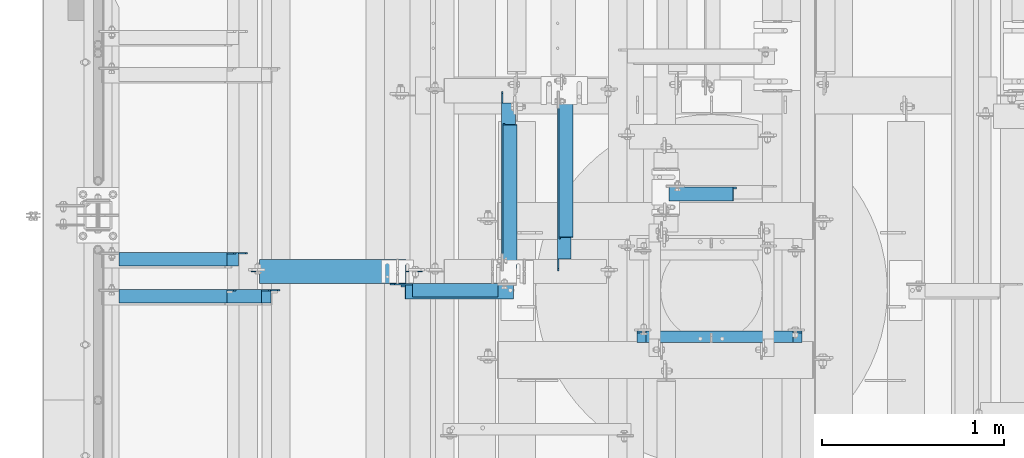
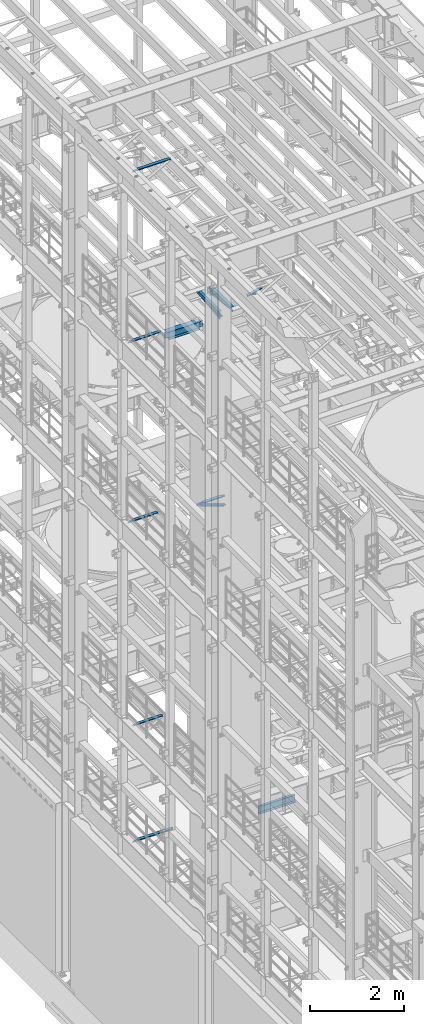
# One storey, part 1257 of 1876: 14 beams, 14 elements without a shape of their own.
"""IFC2X3 building model written with IfcOpenShell, lengths in millimetres."""

from ifc_helpers import new_model, si_unit, frame, origin_with_axes, place, context, subcontext, project, spatial, faceted_brep, material, type_object, element, aggregate, save


model = new_model("IFC2X3")

# Units and contexts
model_context = context("Model", 3, precision=1e-05, world=origin_with_axes())
body_context = subcontext(model_context, "Body", "Model", "MODEL_VIEW")
ifc_project = project(units=[si_unit("LENGTHUNIT", "METRE", prefix="MILLI"), si_unit("AREAUNIT", "SQUARE_METRE"), si_unit("VOLUMEUNIT", "CUBIC_METRE"), si_unit("MASSUNIT", "GRAM", prefix="KILO"), si_unit("TIMEUNIT", "SECOND"), si_unit("PLANEANGLEUNIT", "RADIAN"), si_unit("SOLIDANGLEUNIT", "STERADIAN"), si_unit("THERMODYNAMICTEMPERATUREUNIT", "DEGREE_CELSIUS"), si_unit("LUMINOUSINTENSITYUNIT", "LUMEN")], contexts=[model_context])

# Site, building, storey
site_placement = place(None, origin_with_axes())
site = spatial("IfcSite", under=ifc_project, at=site_placement, CompositionType="ELEMENT")
building_placement = place(site_placement, origin_with_axes())
building = spatial("IfcBuilding", under=site, at=building_placement, Name="Undefined", CompositionType="ELEMENT")
storey_placement = place(building_placement, origin_with_axes())
storey = spatial("IfcBuildingStorey", under=building, at=storey_placement, Name="Undefined", CompositionType="ELEMENT", Elevation=0.0)

# Assembly, beam
assembly_1_placement = place(storey_placement, origin_with_axes())
assembly_1 = element("IfcElementAssembly", 1, at=assembly_1_placement, inside=storey, AssemblyPlace="NOTDEFINED", PredefinedType="RIGID_FRAME")
ifc_material_1 = material(Name="STEEL/A36")
beam_type_1 = type_object("IfcBeamType", Name="L3X3X3/8", PredefinedType="NOTDEFINED")
beam_1_placement = place(assembly_1_placement, frame((2264.97513385575, 5284.27309255047, 17827.8886516946), z_axis=(1.0, 0.0, 0.0), x_axis=(1.46999992831515e-07, 0.993080008006003, 0.117439762000677)))
beam_1 = element("IfcBeam", 2, at=beam_1_placement, type_object=beam_type_1, material=ifc_material_1, ObjectType="L3X3X3/8", context=body_context, shape_type="Brep", body=[
    faceted_brep([(15.9824212601507, 38.1000000000931, -38.0999999999963), (15.9824212619769, 38.1000000000313, 38.1000000000045), (811.054095961969, 38.1000000007734, 38.0999999998535), (811.054095960143, 38.1000000008353, -38.1000000001468), (15.9824212619669, 28.5750000000226, 38.1000000000026), (811.054095961959, 28.5750000007647, 38.0999999998517), (15.9824212603689, 28.5750000000771, -28.574999999998), (811.05409596036, 28.5750000008193, -28.575000000149), (15.9824212602953, -38.1000000000167, -28.5750000000098), (811.054095960287, -38.0999999992782, -28.5750000001613), (15.9824212600679, -38.1000000000095, -38.1000000000104), (811.05409596006, -38.0999999992709, -38.1000000001613)], [[[0, 1, 2, 3]], [[1, 4, 5, 2]], [[4, 6, 7, 5]], [[6, 8, 9, 7]], [[8, 10, 11, 9]], [[10, 0, 3, 11]], [[5, 7, 9, 11, 3, 2]], [[10, 8, 6, 4, 1, 0]]]),
])
aggregate(assembly_1, [beam_1])

assembly_2_placement = place(storey_placement, origin_with_axes())
assembly_2 = element("IfcElementAssembly", 3, at=assembly_2_placement, inside=storey, Name="ANGLE", AssemblyPlace="NOTDEFINED", PredefinedType="RIGID_FRAME")
beam_2_placement = place(assembly_2_placement, frame((2255.45013319264, 5279.79849679511, 17945.1), z_axis=(1.0, 0.0, 0.0), x_axis=(0.0, 1.0, 0.0)))
beam_2 = element("IfcBeam", 4, at=beam_2_placement, type_object=beam_type_1, material=ifc_material_1, Name="ANGLE", ObjectType="L3X3X3/8", context=body_context, shape_type="Brep", body=[
    faceted_brep([(925.116190134668, 28.5750000000007, -28.5750000001863), (925.116201402728, 28.5750000000007, 38.0999999998148), (68.262074232538, 28.5750001907327, 38.0999999999872), (68.2620629644771, 28.5750000000007, -28.5750000000139), (925.116201402728, 38.0999999999985, 38.0999999998148), (68.262074232538, 38.0999999999985, 38.0999999999872), (15.8750625152097, 28.5750000000007, -28.5749999999953), (15.8750613722059, 28.5750001907327, -38.0999999999958), (3.17506156294075, 15.8750003814675, -38.0999999999995), (3.17506270594458, 15.8750003814675, -28.5749999999989), (68.2620613547542, 28.5750001907327, -38.100000000014), (68.2620613547542, 38.0999999999985, -38.100000000014), (925.116188524945, 38.0999999999985, -38.1000000001864), (925.116188524945, 28.5750001907327, -38.1000000001864), (977.503188311244, 28.5750000000007, -28.5750000001963), (977.50318670152, 28.5750001907327, -38.1000000001968), (990.203188120509, 15.8750003814675, -28.575000000199), (990.203186510787, 15.8750003814675, -38.1000000001991), (990.203188120509, 3.17500152587672, -28.575000000199), (990.203186510787, 3.17500152587672, -38.1000000001991), (990.203189649672, -38.0999999999985, -28.575000000199), (990.203188239976, -38.0999999999985, -38.1000000001995), (3.17506206535836, -38.0999999999985, -28.5749999999989), (3.17506108428279, -38.0999999999985, -38.0999999999995), (3.17506156294075, 3.17500152587672, -38.0999999999995), (3.17506270594458, 3.17500152587672, -28.5749999999989)], [[[0, 1, 2, 3]], [[1, 4, 5, 2]], [[6, 7, 8, 9]], [[3, 10, 7, 6]], [[2, 5, 11, 10, 3]], [[4, 12, 11, 5]], [[1, 0, 13, 12, 4]], [[14, 15, 13, 0]], [[16, 17, 15, 14]], [[18, 19, 17, 16]], [[19, 18, 20, 21]], [[21, 20, 22, 23]], [[8, 7, 10, 11, 12, 13, 15, 17, 19, 21, 23, 24]], [[9, 8, 24, 25]], [[20, 18, 16, 14, 0, 3, 6, 9, 25, 22]], [[24, 23, 22, 25]]]),
])
aggregate(assembly_2, [beam_2])

assembly_3_placement = place(storey_placement, origin_with_axes())
assembly_3 = element("IfcElementAssembly", 5, at=assembly_3_placement, inside=storey, AssemblyPlace="NOTDEFINED", PredefinedType="RIGID_FRAME")
beam_3_placement = place(assembly_3_placement, frame((2572.13074474911, 5275.32411137105, 17945.3636516205), z_axis=(1.0, 0.0, 0.0), x_axis=(0.0, 0.993080010016254, -0.117439745001923)))
beam_3 = element("IfcBeam", 6, at=beam_3_placement, type_object=beam_type_1, material=ifc_material_1, ObjectType="L3X3X3/8", context=body_context, shape_type="Brep", body=[
    faceted_brep([(189.245983137666, 38.1000000000895, -38.0999999999999), (189.245983137666, 38.1000000000895, 38.0999999999999), (984.31457199746, 38.1000000005843, 38.0999999999999), (984.31457199746, 38.1000000005843, -38.0999999999999), (189.245983137656, 28.5750000000953, 38.0999999999999), (984.31457199745, 28.5750000005937, 38.0999999999999), (189.245983137656, 28.5750000000953, -28.5749999999998), (984.31457199745, 28.5750000005937, -28.5749999999998), (189.245983137589, -38.0999999998603, -28.5749999999998), (984.314571997383, -38.0999999993655, -28.5749999999998), (189.245983137589, -38.0999999998603, -38.0999999999999), (984.314571997383, -38.0999999993655, -38.0999999999999)], [[[0, 1, 2, 3]], [[1, 4, 5, 2]], [[4, 6, 7, 5]], [[6, 8, 9, 7]], [[8, 10, 11, 9]], [[10, 0, 3, 11]], [[5, 7, 9, 11, 3, 2]], [[10, 8, 6, 4, 1, 0]]]),
])
aggregate(assembly_3, [beam_3])

assembly_4_placement = place(storey_placement, origin_with_axes())
assembly_4 = element("IfcElementAssembly", 7, at=assembly_4_placement, inside=storey, Name="ANGLE", AssemblyPlace="NOTDEFINED", PredefinedType="RIGID_FRAME")
beam_4_placement = place(assembly_4_placement, frame((2562.60574474912, 5279.79856567383, 17945.1), z_axis=(1.0, 0.0, 0.0), x_axis=(0.0, 1.0, 0.0)))
beam_4 = element("IfcBeam", 8, at=beam_4_placement, type_object=beam_type_1, material=ifc_material_1, Name="ANGLE", ObjectType="L3X3X3/8", context=body_context, shape_type="Brep", body=[
    faceted_brep([(925.116125485024, 28.5750000000007, -28.5749999999998), (925.116126885215, 28.5750000000007, 38.0999999999999), (68.2619997150068, 28.5750001907327, 38.0999999999999), (68.2619983148161, 28.5750000000007, -28.5749999999998), (925.116126885217, 38.0999999999985, 38.0999999999999), (68.2619997149695, 38.0999999999985, 38.0999999999999), (15.8749936676099, 28.5749999999989, -28.5750000000007), (15.8749999382144, 28.5750001907327, -38.0999999999999), (3.17500012894925, 15.8750003814675, -38.0999999999999), (3.17500032897624, 15.8750003814675, -28.5749999999998), (68.2619981147891, 28.5750001907327, -38.0999999999999), (68.2619981147864, 38.0999999999985, -38.0999999999999), (925.116125285034, 38.0999999999985, -38.0999999999999), (925.116125284997, 28.5750001907327, -38.0999999999999), (977.503123661599, 28.5750000000007, -28.5749999999998), (977.503123461572, 28.5750001907327, -38.0999999999999), (990.203123470864, 15.8750003814675, -28.5749999999998), (990.203123270837, 15.8750003814675, -38.0999999999999), (990.203123470864, 3.17500152587672, -28.5749999999998), (990.203123270837, 3.17500152587672, -38.0999999999999), (990.203125000004, -38.0999999999985, -28.5749999999998), (990.203125000004, -38.0999999999985, -38.0999999999999), (3.17499999075153, -38.0999999999985, -28.5749999999998), (3.17499999075153, -38.0999999999985, -38.0999999999999), (3.17500012894925, 3.17500152587672, -38.0999999999999), (3.17500032897624, 3.17500152587672, -28.5749999999998)], [[[0, 1, 2, 3]], [[1, 4, 5, 2]], [[6, 7, 8, 9]], [[3, 10, 7, 6]], [[2, 5, 11, 10, 3]], [[4, 12, 11, 5]], [[1, 0, 13, 12, 4]], [[14, 15, 13, 0]], [[16, 17, 15, 14]], [[18, 19, 17, 16]], [[19, 18, 20, 21]], [[21, 20, 22, 23]], [[8, 7, 10, 11, 12, 13, 15, 17, 19, 21, 23, 24]], [[9, 8, 24, 25]], [[20, 18, 16, 14, 0, 3, 6, 9, 25, 22]], [[24, 23, 22, 25]]]),
])
aggregate(assembly_4, [beam_4])

assembly_5_placement = place(storey_placement, origin_with_axes())
assembly_5 = element("IfcElementAssembly", 9, at=assembly_5_placement, inside=storey, AssemblyPlace="NOTDEFINED", PredefinedType="RIGID_FRAME")
beam_5_placement = place(assembly_5_placement, frame((3121.40550695098, 5705.49027389162, 17827.625), z_axis=(0.0, -1.0, 0.0), x_axis=(0.96921335566298, -1.16999989788286e-07, 0.246222401914391)))
beam_5 = element("IfcBeam", 10, at=beam_5_placement, type_object=beam_type_1, material=ifc_material_1, ObjectType="L3X3X3/8", context=body_context, shape_type="Brep", body=[
    faceted_brep([(26.0583260141784, 38.0999999999804, -38.1000000000095), (26.0583259932782, 38.1000000000859, 38.0999999999913), (391.609254057234, 38.1000000001732, 38.1000000000377), (391.609254078135, 38.1000000000677, -38.0999999999631), (26.0583259932764, 28.5750000000808, 38.0999999999949), (391.609254057231, 28.5750000001644, 38.1000000000413), (26.0583260115645, 28.5749999999862, -28.5750000000062), (391.609254075521, 28.5750000000698, -28.5749999999598), (26.0583260115518, -38.1000000000604, -28.5749999999844), (391.609254075506, -38.0999999999767, -28.5749999999389), (26.0583260141639, -38.1000000000713, -38.0999999999858), (391.609254078118, -38.0999999999876, -38.0999999999394)], [[[0, 1, 2, 3]], [[1, 4, 5, 2]], [[4, 6, 7, 5]], [[6, 8, 9, 7]], [[8, 10, 11, 9]], [[10, 0, 3, 11]], [[5, 7, 9, 11, 3, 2]], [[10, 8, 6, 4, 1, 0]]]),
])
aggregate(assembly_5, [beam_5])

assembly_6_placement = place(storey_placement, origin_with_axes())
assembly_6 = element("IfcElementAssembly", 11, at=assembly_6_placement, inside=storey, AssemblyPlace="NOTDEFINED", PredefinedType="RIGID_FRAME")
beam_6_placement = place(assembly_6_placement, frame((1587.51955351427, 5166.5618484497, 13273.6720682906), z_axis=(0.0, -1.0, 0.0), x_axis=(0.942990333545967, 0.0, -0.332820117839752)))
beam_6 = element("IfcBeam", 12, at=beam_6_placement, type_object=beam_type_1, material=ifc_material_1, ObjectType="L3X3X3/8", context=body_context, shape_type="Brep", body=[
    faceted_brep([(95.3968786089349, 38.100000000044, -38.1000000000004), (95.3968786089349, 38.100000000044, 38.1000000000004), (726.419164255835, 38.1000000003787, 38.1000000000004), (726.419164255835, 38.1000000003787, -38.1000000000004), (95.3968786089299, 28.5750000000462, 38.1000000000004), (726.41916425583, 28.5750000003809, 38.1000000000004), (95.3968786089299, 28.5750000000462, -28.5749999999998), (726.41916425583, 28.5750000003809, -28.5749999999998), (95.3968786088958, -38.0999999999422, -28.5749999999998), (726.419164255796, -38.0999999996093, -28.5749999999998), (95.3968786088958, -38.0999999999422, -38.1000000000004), (726.419164255796, -38.0999999996093, -38.1000000000004)], [[[0, 1, 2, 3]], [[1, 4, 5, 2]], [[4, 6, 7, 5]], [[6, 8, 9, 7]], [[8, 10, 11, 9]], [[10, 0, 3, 11]], [[5, 7, 9, 11, 3, 2]], [[10, 8, 6, 4, 1, 0]]]),
])
aggregate(assembly_6, [beam_6])

assembly_7_placement = place(storey_placement, origin_with_axes())
assembly_7 = element("IfcElementAssembly", 13, at=assembly_7_placement, inside=storey, Name="ANGLE", AssemblyPlace="NOTDEFINED", PredefinedType="RIGID_FRAME")
beam_7_placement = place(assembly_7_placement, frame((1600.2, 5176.08684844971, 13271.5), z_axis=(0.0, -1.0, 0.0), x_axis=(1.0, 0.0, 0.0)))
beam_7 = element("IfcBeam", 14, at=beam_7_placement, type_object=beam_type_1, material=ifc_material_1, Name="ANGLE", ObjectType="L3X3X3/8", context=body_context, shape_type="Brep", body=[
    faceted_brep([(128.586999858062, 38.1000000000004, 38.1000000000004), (128.586999858057, 28.5750000000007, 38.1000000000004), (598.488001267657, 28.5750000000007, 38.1000000000004), (598.488001267657, 38.1000000000004, 38.1000000000004), (128.586999057965, 28.5750000000007, -28.5749999999998), (598.488000334217, 28.5750000000007, -28.5749999999998), (672.306247175647, 22.2250007629409, -28.5749999999998), (672.306247042299, 22.2250007629409, -38.1000000000004), (598.488000200868, 22.2250007629409, -38.1000000000004), (598.488000334217, 22.2250007629409, -28.5749999999998), (598.488000200868, 38.1000000000004, -38.1000000000004), (128.586998943671, 38.1000000000004, -38.1000000000004), (128.586998943663, 19.0499996185299, -38.1000000000004), (128.586999057964, 19.0499996185299, -28.5749999999998), (30.9562521022438, 19.0499996185299, -38.1000000000004), (30.9562522165447, 19.0499996185299, -28.5749999999998), (5.55625248371348, -6.35000000000036, -38.1000000000004), (5.55625259801445, -6.35000000000036, -28.5749999999998), (5.55625000000055, -38.1000000000004, -38.1000000000004), (5.55625000000055, -38.1000000000004, -28.5749999999998), (697.70625, -38.1000000000004, -28.5749999999998), (697.706246794178, -3.175000762938, -28.5749999999998), (697.706246660829, -3.175000762938, -38.1000000000004), (697.70625, -38.1000000000004, -38.1000000000004)], [[[0, 1, 2, 3]], [[1, 4, 5, 2]], [[6, 7, 8, 9]], [[2, 5, 9, 8, 10, 3]], [[11, 0, 3, 10]], [[1, 0, 11, 12, 13, 4]], [[13, 12, 14, 15]], [[15, 14, 16, 17]], [[16, 18, 19, 17]], [[6, 9, 5, 4, 13, 15, 17, 19, 20, 21]], [[7, 6, 21, 22]], [[18, 16, 14, 12, 11, 10, 8, 7, 22, 23]], [[19, 18, 23, 20]], [[22, 21, 20, 23]]]),
])
aggregate(assembly_7, [beam_7])

assembly_8_placement = place(storey_placement, origin_with_axes())
assembly_8 = element("IfcElementAssembly", 15, at=assembly_8_placement, inside=storey, Name="ANGLE", AssemblyPlace="NOTDEFINED", PredefinedType="RIGID_FRAME")
beam_8_placement = place(assembly_8_placement, frame((4.51516825708356e-09, 5143.5, 22517.1), z_axis=(0.0, -1.0, 0.0), x_axis=(1.0, 0.0, 0.0)))
beam_8 = element("IfcBeam", 16, at=beam_8_placement, type_object=beam_type_1, material=ifc_material_1, Name="ANGLE", ObjectType="L3X3X3/8", context=body_context, shape_type="Brep", body=[
    faceted_brep([(115.886999817316, 28.5750000000007, 38.0999999999999), (115.886999817316, 38.0999999999985, 38.0999999999999), (115.886998826692, 38.0999999999985, -38.0999999999999), (115.88699882669, 12.699999237062, -38.0999999999999), (115.886998950515, 12.699999237062, -28.5749999999998), (115.88699895052, 28.5750000000007, -28.5749999999998), (38.8937432114558, 12.699999237062, -38.0999999999999), (38.8937433352807, 12.699999237062, -28.5749999999998), (7.14374321145577, -19.050000762938, -38.0999999999999), (7.14374333528067, -19.050000762938, -28.5749999999998), (7.1437499954859, -38.0999999999985, -38.0999999999999), (7.1437499954859, -38.0999999999985, -28.5749999999998), (949.325002419604, 15.8750003814712, -28.5749999999998), (936.625002610339, 28.5750000000007, -28.5749999999998), (900.113000619098, 28.5750000000007, -28.5749999999998), (949.324999995485, -38.0999999999985, -28.5749999999998), (949.325002419604, 3.17500152588036, -28.5749999999998), (900.11300241932, 28.5750000000007, 38.0999999999999), (900.1130024193, 38.0999999999985, 38.0999999999999), (900.113000361957, 38.0999999999985, -38.0999999999999), (900.113000361924, 28.5750001907363, -38.0999999999999), (936.625002353164, 28.5750001907363, -38.0999999999999), (949.325002162429, 15.8750003814712, -38.0999999999999), (949.325002162429, 3.17500152588036, -38.0999999999999), (949.324999995485, -38.0999999999985, -38.0999999999999)], [[[0, 1, 2, 3, 4, 5]], [[4, 3, 6, 7]], [[7, 6, 8, 9]], [[8, 10, 11, 9]], [[12, 13, 14, 5, 4, 7, 9, 11, 15, 16]], [[0, 5, 14, 17]], [[1, 0, 17, 18]], [[2, 1, 18, 19]], [[17, 14, 20, 19, 18]], [[13, 21, 20, 14]], [[12, 22, 21, 13]], [[16, 23, 22, 12]], [[10, 8, 6, 3, 2, 19, 20, 21, 22, 23, 24]], [[11, 10, 24, 15]], [[23, 16, 15, 24]]]),
])
aggregate(assembly_8, [beam_8])

assembly_9_placement = place(storey_placement, origin_with_axes())
assembly_9 = element("IfcElementAssembly", 17, at=assembly_9_placement, inside=storey, Name="ANGLE", AssemblyPlace="NOTDEFINED", PredefinedType="RIGID_FRAME")
beam_9_placement = place(assembly_9_placement, frame((-1.44313229599957e-09, 5346.7, 17945.1), z_axis=(0.0, -1.0, 0.0), x_axis=(1.0, 0.0, 0.0)))
beam_9 = element("IfcBeam", 18, at=beam_9_placement, type_object=beam_type_1, material=ifc_material_1, Name="ANGLE", ObjectType="L3X3X3/8", context=body_context, shape_type="Brep", body=[
    faceted_brep([(773.112500001443, 28.5750000000007, -28.5749999999998), (773.112500001443, 28.5750000000007, 38.0999999999999), (115.886999817316, 28.5750000000007, 38.0999999999999), (115.88699895052, 28.5750000000007, -28.5749999999998), (773.112500001443, 38.0999999999985, 38.0999999999999), (115.886999817316, 38.0999999999985, 38.0999999999999), (115.886998950515, 12.699999237062, -28.5749999999998), (115.88699882669, 12.699999237062, -38.0999999999999), (38.8937432114558, 12.699999237062, -38.0999999999999), (38.8937433352807, 12.699999237062, -28.5749999999998), (115.886998826692, 38.0999999999985, -38.0999999999999), (773.112500001443, 38.0999999999985, -38.1000000000004), (773.112500001443, 28.5750000000007, -38.1000000000004), (809.625001718057, 28.5750000000007, -28.5749999999998), (809.625001718057, 28.5750000000007, -38.1000000000004), (822.325001527322, 15.8750001907356, -28.5749999999998), (822.325001527322, 15.8750001907356, -38.1000000000004), (822.325001527322, -38.1000030517571, -28.5749999999998), (822.325001527322, -38.0999999999985, -38.1000000000004), (7.1437499954859, -38.0999999999985, -28.5749999999998), (7.1437499954859, -38.0999999999985, -38.0999999999999), (7.14374321145577, -19.050000762938, -38.0999999999999), (7.14374333528067, -19.050000762938, -28.5749999999998)], [[[0, 1, 2, 3]], [[1, 4, 5, 2]], [[6, 7, 8, 9]], [[2, 5, 10, 7, 6, 3]], [[4, 11, 10, 5]], [[1, 0, 12, 11, 4]], [[13, 14, 12, 0]], [[15, 16, 14, 13]], [[17, 18, 16, 15]], [[18, 17, 19, 20]], [[8, 7, 10, 11, 12, 14, 16, 18, 20, 21]], [[9, 8, 21, 22]], [[17, 15, 13, 0, 3, 6, 9, 22, 19]], [[21, 20, 19, 22]]]),
])
aggregate(assembly_9, [beam_9])

assembly_10_placement = place(storey_placement, origin_with_axes())
assembly_10 = element("IfcElementAssembly", 19, at=assembly_10_placement, inside=storey, Name="ANGLE", AssemblyPlace="NOTDEFINED", PredefinedType="RIGID_FRAME")
beam_10_placement = place(assembly_10_placement, frame((0.0, 5143.5, 8115.3), z_axis=(0.0, -1.0, 0.0), x_axis=(1.0, 0.0, 0.0)))
beam_10 = element("IfcBeam", 20, at=beam_10_placement, type_object=beam_type_1, material=ifc_material_1, Name="ANGLE", ObjectType="L3X3X3/8", context=body_context, shape_type="Brep", body=[
    faceted_brep([(115.886999817316, 28.5750000000007, 38.0999999999999), (115.886999817316, 38.0999999999985, 38.0999999999999), (115.886998826692, 38.0999999999985, -38.0999999999999), (115.88699882669, 12.699999237062, -38.0999999999999), (115.886998950515, 12.699999237062, -28.5749999999998), (115.88699895052, 28.5750000000007, -28.5749999999998), (38.8937432114558, 12.699999237062, -38.0999999999999), (38.8937433352807, 12.699999237062, -28.5749999999998), (7.14374321145577, -19.050000762938, -38.0999999999999), (7.14374333528067, -19.050000762938, -28.5749999999998), (7.1437499954859, -38.0999999999985, -38.0999999999999), (7.1437499954859, -38.0999999999985, -28.5749999999998), (758.825002424117, 15.8750003814712, -28.5749999999998), (746.125002614852, 28.5749999999998, -28.5749999999998), (709.61300062358, 28.5749999999998, -28.5749999999998), (758.824999999999, -38.1000000000004, -28.5749999999998), (758.825002424117, 3.17500152588036, -28.5749999999998), (709.613002423808, 28.5749999999998, 38.1000000000004), (709.613002423808, 38.1000000000004, 38.1000000000004), (709.613000366395, 38.1000000000004, -38.1000000000004), (709.613000366404, 28.5750001907363, -38.1000000000004), (746.125002357676, 28.5750001907363, -38.1000000000004), (758.825002166941, 15.8750003814712, -38.1000000000004), (758.825002166941, 3.17500152588036, -38.1000000000004), (758.824999999999, -38.1000000000004, -38.1000000000004)], [[[0, 1, 2, 3, 4, 5]], [[4, 3, 6, 7]], [[7, 6, 8, 9]], [[8, 10, 11, 9]], [[12, 13, 14, 5, 4, 7, 9, 11, 15, 16]], [[0, 5, 14, 17]], [[1, 0, 17, 18]], [[2, 1, 18, 19]], [[17, 14, 20, 19, 18]], [[13, 21, 20, 14]], [[12, 22, 21, 13]], [[16, 23, 22, 12]], [[10, 8, 6, 3, 2, 19, 20, 21, 22, 23, 24]], [[11, 10, 24, 15]], [[23, 16, 15, 24]]]),
])
aggregate(assembly_10, [beam_10])

assembly_11_placement = place(storey_placement, origin_with_axes())
assembly_11 = element("IfcElementAssembly", 21, at=assembly_11_placement, inside=storey, Name="ANGLE", AssemblyPlace="NOTDEFINED", PredefinedType="RIGID_FRAME")
beam_11_placement = place(assembly_11_placement, frame((0.0, 5143.5, 5092.7), z_axis=(0.0, -1.0, 0.0), x_axis=(1.0, 0.0, 0.0)))
beam_11 = element("IfcBeam", 22, at=beam_11_placement, type_object=beam_type_1, material=ifc_material_1, Name="ANGLE", ObjectType="L3X3X3/8", context=body_context, shape_type="Brep", body=[
    faceted_brep([(115.886999817316, 28.5750000000007, 38.0999999999999), (115.886999817316, 38.0999999999985, 38.0999999999999), (115.886998826692, 38.0999999999985, -38.0999999999999), (115.88699882669, 12.699999237062, -38.0999999999999), (115.886998950515, 12.699999237062, -28.5749999999998), (115.88699895052, 28.5750000000007, -28.5749999999998), (38.8937432114558, 12.699999237062, -38.0999999999999), (38.8937433352807, 12.699999237062, -28.5749999999998), (7.14374321145577, -19.050000762938, -38.0999999999999), (7.14374333528067, -19.050000762938, -28.5749999999998), (7.1437499954859, -38.0999999999985, -38.0999999999999), (7.1437499954859, -38.0999999999985, -28.5749999999998), (1000.12500242412, 15.8750003814712, -28.5749999999998), (987.425002614851, 28.5749999999998, -28.5749999999998), (950.913000303442, 28.5749999999998, -28.5749999999998), (1000.12500001551, -38.1000000000004, -28.5749999999998), (1000.12500242412, 3.17500152588036, -28.5749999999998), (950.913001170238, 28.5749999999998, 38.0999999999999), (950.913001170238, 38.1000000000004, 38.0999999999999), (950.913000179614, 38.1000000000004, -38.0999999999999), (950.913000366403, 28.5750001907363, -38.0999999999999), (987.425002357675, 28.5750001907363, -38.0999999999999), (1000.12500216694, 15.8750003814712, -38.0999999999999), (1000.12500216694, 3.17500152588036, -38.0999999999999), (1000.12500001551, -38.1000000000004, -38.0999999999999)], [[[0, 1, 2, 3, 4, 5]], [[4, 3, 6, 7]], [[7, 6, 8, 9]], [[8, 10, 11, 9]], [[12, 13, 14, 5, 4, 7, 9, 11, 15, 16]], [[0, 5, 14, 17]], [[1, 0, 17, 18]], [[2, 1, 18, 19]], [[17, 14, 20, 19, 18]], [[13, 21, 20, 14]], [[12, 22, 21, 13]], [[16, 23, 22, 12]], [[10, 8, 6, 3, 2, 19, 20, 21, 22, 23, 24]], [[11, 10, 24, 15]], [[23, 16, 15, 24]]]),
])
aggregate(assembly_11, [beam_11])

assembly_12_placement = place(storey_placement, origin_with_axes())
assembly_12 = element("IfcElementAssembly", 23, at=assembly_12_placement, inside=storey, Name="ANGLE", AssemblyPlace="NOTDEFINED", PredefinedType="RIGID_FRAME")
beam_12_placement = place(assembly_12_placement, frame((-8.61482369428009e-09, 5346.7, 13271.5), z_axis=(0.0, -1.0, 0.0), x_axis=(1.0, 0.0, 0.0)))
beam_12 = element("IfcBeam", 24, at=beam_12_placement, type_object=beam_type_1, material=ifc_material_1, Name="ANGLE", ObjectType="L3X3X3/8", context=body_context, shape_type="Brep", body=[
    faceted_brep([(115.886999817316, 28.5750000000007, 38.0999999999999), (115.886999817316, 38.0999999999985, 38.0999999999999), (115.886998826692, 38.0999999999985, -38.0999999999999), (115.88699882669, 12.699999237062, -38.0999999999999), (115.886998950515, 12.699999237062, -28.5749999999998), (115.88699895052, 28.5750000000007, -28.5749999999998), (38.8937432114558, 12.699999237062, -38.0999999999999), (38.8937433352807, 12.699999237062, -28.5749999999998), (7.14374321145577, -19.050000762938, -38.0999999999999), (7.14374333528067, -19.050000762938, -28.5749999999998), (7.1437499954859, -38.0999999999985, -38.0999999999999), (7.1437499954859, -38.0999999999985, -28.5749999999998), (758.82500204062, 14.2880005577626, -28.5749999999998), (746.125002396449, 26.9880005321429, -28.5749999999998), (709.613000600291, 26.9880010068428, -28.5749999999998), (709.61300062358, 28.5749999999998, -28.5749999999998), (758.824999999999, -38.1000000000004, -28.5749999999998), (758.825001875526, 1.58799979482319, -28.5749999999998), (709.613002423808, 28.5749999999998, 38.1000000000004), (709.613002423808, 38.1000000000004, 38.1000000000004), (709.613000366395, 38.1000000000004, -38.1000000000004), (709.613000343115, 26.9880010068428, -38.1000000000004), (746.125002139273, 26.9880005321429, -38.1000000000004), (758.825001783445, 14.2880005577626, -38.1000000000004), (758.825001618351, 1.58799979482319, -38.1000000000004), (758.824999999999, -38.1000000000004, -38.1000000000004)], [[[0, 1, 2, 3, 4, 5]], [[4, 3, 6, 7]], [[7, 6, 8, 9]], [[8, 10, 11, 9]], [[12, 13, 14, 15, 5, 4, 7, 9, 11, 16, 17]], [[0, 5, 15, 18]], [[1, 0, 18, 19]], [[2, 1, 19, 20]], [[18, 15, 14, 21, 20, 19]], [[13, 22, 21, 14]], [[12, 23, 22, 13]], [[17, 24, 23, 12]], [[10, 8, 6, 3, 2, 20, 21, 22, 23, 24, 25]], [[11, 10, 25, 16]], [[24, 17, 16, 25]]]),
])
aggregate(assembly_12, [beam_12])

assembly_13_placement = place(storey_placement, origin_with_axes())
assembly_13 = element("IfcElementAssembly", 25, at=assembly_13_placement, inside=storey, Name="BEAM", AssemblyPlace="NOTDEFINED", PredefinedType="RIGID_FRAME")
ifc_material_2 = material(Name="STEEL/A992")
beam_type_2 = type_object("IfcBeamType", Name="W8X18", PredefinedType="NOTDEFINED")
beam_13_placement = place(assembly_13_placement, frame((828.674999999999, 5279.79856567383, 17880.0125), z_axis=(0.0, 0.0, 1.0), x_axis=(1.0, 0.0, 0.0)))
beam_13 = element("IfcBeam", 26, at=beam_13_placement, type_object=beam_type_2, material=ifc_material_2, Name="BEAM", ObjectType="W8X18", context=body_context, shape_type="Brep", body=[
    faceted_brep([(865.1875, -66.6750000000002, -103.1875), (865.1875, 66.6750000000002, -103.1875), (865.1875, 66.6750000000002, -96.8374998092659), (865.1875, -66.6750000000002, -96.8374998092659), (865.503273345276, -3.17500000000018, -95.25), (865.503273345276, -66.6750000000002, -95.25), (865.503273345276, 66.6750000000002, -95.25), (865.503273345276, 3.17500000000018, -95.25), (866.154229922588, 3.17500000000018, -91.9774202912195), (866.154229922588, -3.17500000000018, -91.9774202912195), (868.907243823066, 3.17500000000018, -87.8572438230658), (868.907243823066, -3.17500000000018, -87.8572438230658), (873.02742029122, 3.17500000000018, -85.1042299225883), (873.02742029122, -3.17500000000018, -85.1042299225883), (877.887499809265, 3.17500000000018, -84.1375000000007), (877.887499809265, -3.17500000000018, -84.1375000000007), (954.0875, -3.17500000000018, -84.1375000000007), (954.0875, 3.17500000000018, -84.1375000000007), (60.3249999999998, -66.6750000000002, 103.1875), (60.3249999999998, 66.6750000000002, 103.1875), (60.3249999999998, 66.6750000000002, 96.8374998092695), (60.3249999999998, -66.6750000000002, 96.8374998092695), (60.0092266547233, 3.17500000000018, 95.25), (60.0092266547233, 66.6750000000002, 95.25), (865.1875, 66.6750000000002, 95.25), (865.1875, 3.17500000000018, 95.25), (104.775000000001, -3.17500000000018, -90.4874998092673), (104.775000000001, 3.17500000000018, -90.4874998092673), (104.775000000001, 3.17500000000018, -95.25), (104.775000000001, 66.6750000000002, -95.25), (104.775000000001, 66.6750000000002, -103.1875), (104.775000000001, -66.6750000000002, -103.1875), (104.775000000001, -66.6750000000002, -95.25), (104.775000000001, -3.17500000000018, -95.25), (103.808270077413, -3.17500000000018, -85.6274202912209), (103.808270077413, 3.17500000000018, -85.6274202912209), (101.055256176935, -3.17500000000018, -81.5072438230673), (101.055256176935, 3.17500000000018, -81.5072438230673), (96.9350797087809, -3.17500000000018, -78.7542299225897), (96.9350797087809, 3.17500000000018, -78.7542299225897), (92.0750001907354, -3.17500000000018, -77.7875000000022), (92.0750001907354, 3.17500000000018, -77.7875000000022), (12.7000000000007, -3.17500000000018, -77.7875000000022), (12.7000000000007, 3.17500000000018, -77.7875000000022), (12.7, -3.17500000000018, 84.1375000000044), (12.7, 3.17500000000018, 84.1375000000044), (47.6250001907347, -3.17500000000018, 84.1375000000044), (47.6250001907347, 3.17500000000018, 84.1375000000044), (52.4850797087803, -3.17500000000018, 85.1042299225919), (52.4850797087803, 3.17500000000018, 85.1042299225919), (56.6052561769339, -3.17500000000018, 87.8572438230694), (56.6052561769339, 3.17500000000018, 87.8572438230694), (59.358270077412, -3.17500000000018, 91.9774202912231), (59.358270077412, 3.17500000000018, 91.9774202912231), (60.0092266547233, -3.17500000000018, 95.25), (60.0092266547233, -66.6750000000002, 95.25), (865.1875, -3.17500000000018, 95.25), (865.1875, -66.6750000000002, 95.25), (865.1875, -66.6750000000002, 103.1875), (865.1875, 66.6750000000002, 103.1875), (865.1875, -3.17500000000018, 84.1374998092651), (865.1875, 3.17500000000018, 84.1374998092651), (866.154229922588, -3.17500000000018, 79.2774202912187), (866.154229922588, 3.17500000000018, 79.2774202912187), (868.907243823066, -3.17500000000018, 75.1572438230651), (868.907243823066, 3.17500000000018, 75.1572438230651), (873.027420291219, -3.17500000000018, 72.4042299225875), (873.027420291219, 3.17500000000018, 72.4042299225875), (877.887499809265, -3.17500000000018, 71.4375), (877.887499809265, 3.17500000000018, 71.4375), (954.0875, -3.17500000000018, 71.4375), (954.0875, 3.17500000000018, 71.4375)], [[[0, 1, 2, 3]], [[4, 5, 3, 2, 6, 7, 8, 9]], [[9, 8, 10, 11]], [[11, 10, 12, 13]], [[13, 12, 14, 15]], [[16, 15, 14, 17]], [[18, 19, 20, 21]], [[22, 23, 24, 25]], [[26, 27, 28, 29, 30, 31, 32, 33]], [[34, 35, 27, 26]], [[36, 37, 35, 34]], [[38, 39, 37, 36]], [[40, 41, 39, 38]], [[42, 43, 41, 40]], [[44, 45, 43, 42]], [[46, 47, 45, 44]], [[48, 49, 47, 46]], [[50, 51, 49, 48]], [[52, 53, 51, 50]], [[21, 20, 23, 22, 53, 52, 54, 55]], [[55, 54, 56, 57]], [[18, 21, 55, 57, 58]], [[19, 18, 58, 59]], [[23, 20, 19, 59, 24]], [[58, 57, 56, 60, 61, 25, 24, 59]], [[62, 63, 61, 60]], [[64, 65, 63, 62]], [[66, 67, 65, 64]], [[68, 69, 67, 66]], [[70, 71, 69, 68]], [[71, 70, 16, 17]], [[12, 10, 8, 7, 28, 27, 35, 37, 39, 41, 43, 45, 47, 49, 51, 53, 22, 25, 61, 63, 65, 67, 69, 71, 17, 14]], [[29, 28, 7, 6]], [[1, 30, 29, 6, 2]], [[31, 30, 1, 0]], [[32, 31, 0, 3, 5]], [[33, 32, 5, 4]], [[70, 68, 66, 64, 62, 60, 56, 54, 52, 50, 48, 46, 44, 42, 40, 38, 36, 34, 26, 33, 4, 9, 11, 13, 15, 16]]]),
])
aggregate(assembly_13, [beam_13])

assembly_14_placement = place(storey_placement, origin_with_axes())
assembly_14 = element("IfcElementAssembly", 27, at=assembly_14_placement, inside=storey, Name="BEAM", AssemblyPlace="NOTDEFINED", PredefinedType="RIGID_FRAME")
beam_type_3 = type_object("IfcBeamType", Name="C8X18.75", PredefinedType="NOTDEFINED")
beam_14_placement = place(assembly_14_placement, frame((2882.9, 4922.0028503418, 5029.2), z_axis=(0.0, 0.0, 1.0), x_axis=(1.0, 0.0, 0.0)))
beam_14 = element("IfcBeam", 28, at=beam_14_placement, type_object=beam_type_3, material=ifc_material_1, Name="BEAM", ObjectType="C8X18.75", context=body_context, shape_type="Brep", body=[
    faceted_brep([(936.625, -31.75, 101.6), (936.625, -31.75, 97.3645500000002), (936.625, -19.0576219043487, 95.2499998092644), (936.625, 31.75, 95.2499998092644), (936.625, 31.75, 101.6), (937.591729922587, 10.1145240623118, 90.3899202912189), (937.591729922587, 31.75, 90.3899202912189), (940.344743823066, 19.0500000000002, 86.2697438230653), (940.344743823066, 31.75, 86.2697438230653), (938.586414246512, 19.0500000000002, 88.9012700000003), (944.464920291219, 19.0500000000002, 83.5167299225868), (944.464920291219, 31.75, 83.5167299225868), (949.324999809265, 19.0500000000002, 82.5499999999993), (949.324999809265, 31.75, 82.5499999999993), (987.425, 19.0500000000002, 82.5499999999993), (987.425, 31.75, 82.5499999999993), (130.175000000002, -31.75, 101.6), (130.175000000002, 31.75, 101.6), (130.175000000002, 31.75, 95.2499998092644), (130.175000000002, -19.0576219043487, 95.2499998092644), (130.175000000002, -31.75, 97.3645500000002), (129.208270077414, 31.75, 90.3899202912189), (129.208270077414, 10.1145240623118, 90.3899202912189), (126.455256176936, 31.75, 86.2697438230653), (126.455256176936, 19.0500000000002, 86.2697438230653), (128.213585753489, 19.0500000000002, 88.9012700000003), (122.335079708782, 31.75, 83.5167299225868), (122.335079708782, 19.0500000000002, 83.5167299225868), (117.475000190736, 31.75, 82.5499999999993), (117.475000190736, 19.0500000000002, 82.5499999999993), (79.3750000000009, 31.75, 82.5499999999993), (79.3750000000009, 19.0500000000002, 82.5499999999993), (79.3750000000009, 31.75, -101.6), (79.3750000000009, -31.75, -101.6), (79.3750000000009, -31.75, -97.3645500000002), (79.3750000000009, 19.0500000000002, -88.9012700000003), (987.425, 31.75, -101.6), (987.425, -31.75, -101.6), (987.425, -31.75, -97.3645500000002), (987.425, 19.0500000000002, -88.9012700000003)], [[[0, 1, 2, 3, 4]], [[5, 6, 3, 2]], [[7, 8, 6, 5, 9]], [[10, 11, 8, 7]], [[12, 13, 11, 10]], [[14, 15, 13, 12]], [[16, 17, 18, 19, 20]], [[19, 18, 21, 22]], [[22, 21, 23, 24, 25]], [[24, 23, 26, 27]], [[27, 26, 28, 29]], [[29, 28, 30, 31]], [[32, 33, 34, 35, 31, 30]], [[33, 32, 36, 37]], [[34, 33, 37, 38]], [[35, 34, 38, 39]], [[10, 7, 9, 25, 24, 27, 29, 31, 35, 39, 14, 12]], [[2, 1, 20, 19, 22, 25, 9, 5]], [[16, 20, 1, 0]], [[17, 16, 0, 4]], [[36, 32, 30, 28, 26, 23, 21, 18, 17, 4, 3, 6, 8, 11, 13, 15]], [[39, 38, 37, 36, 15, 14]]]),
])
aggregate(assembly_14, [beam_14])

save(model, "model.ifc")
